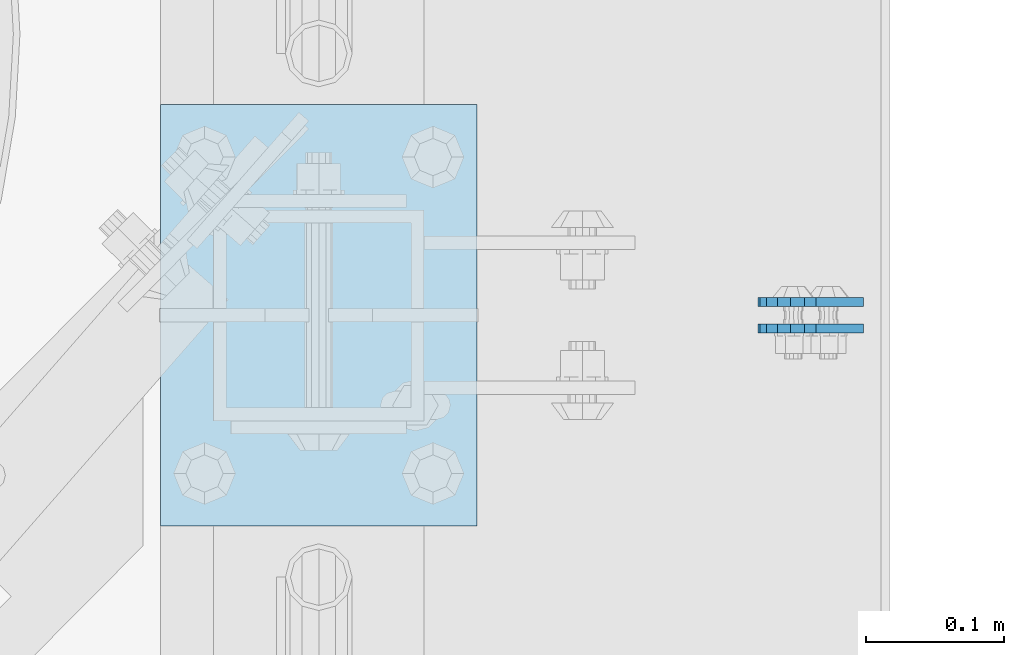
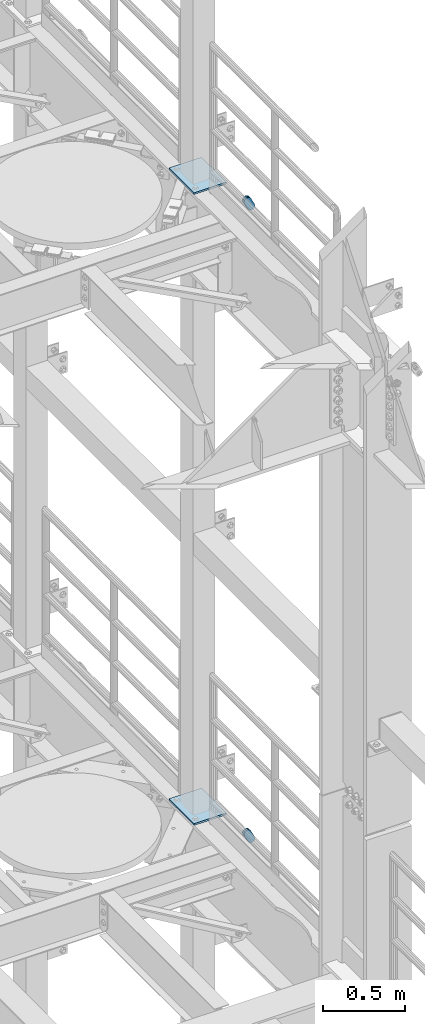
# One storey, part 1677 of 1876: 6 plates, 6 elements without a shape of their own.
"""IFC2X3 building model written with IfcOpenShell, lengths in millimetres."""

from ifc_helpers import new_model, si_unit, frame, origin_with_axes, place, context, subcontext, project, spatial, faceted_brep, material, type_object, element, aggregate, save


model = new_model("IFC2X3")

# Units and contexts
model_context = context("Model", 3, precision=1e-05, world=origin_with_axes())
body_context = subcontext(model_context, "Body", "Model", "MODEL_VIEW")
ifc_project = project(units=[si_unit("LENGTHUNIT", "METRE", prefix="MILLI"), si_unit("AREAUNIT", "SQUARE_METRE"), si_unit("VOLUMEUNIT", "CUBIC_METRE"), si_unit("MASSUNIT", "GRAM", prefix="KILO"), si_unit("TIMEUNIT", "SECOND"), si_unit("PLANEANGLEUNIT", "RADIAN"), si_unit("SOLIDANGLEUNIT", "STERADIAN"), si_unit("THERMODYNAMICTEMPERATUREUNIT", "DEGREE_CELSIUS"), si_unit("LUMINOUSINTENSITYUNIT", "LUMEN")], contexts=[model_context])

# Site, building, storey
site_placement = place(None, origin_with_axes())
site = spatial("IfcSite", under=ifc_project, at=site_placement, CompositionType="ELEMENT")
building_placement = place(site_placement, origin_with_axes())
building = spatial("IfcBuilding", under=site, at=building_placement, Name="Undefined", CompositionType="ELEMENT")
storey_placement = place(building_placement, origin_with_axes())
storey = spatial("IfcBuildingStorey", under=building, at=storey_placement, Name="Undefined", CompositionType="ELEMENT", Elevation=0.0)

# Assembly, plate
assembly_1_placement = place(storey_placement, origin_with_axes())
assembly_1 = element("IfcElementAssembly", 1, at=assembly_1_placement, inside=storey, Name="PLATE", AssemblyPlace="NOTDEFINED", PredefinedType="RIGID_FRAME")
ifc_material = material(Name="STEEL/A36")
plate_type_1 = type_object("IfcPlateType", PredefinedType="NOTDEFINED")
plate_1_placement = place(assembly_1_placement, frame((7974.16265106339, 3546.47500383818, 17725.1776774809), z_axis=(-0.894427191199917, 1.49999996210681e-08, -0.447213595099955), x_axis=(0.447213595099955, -6.99999707257281e-09, -0.894427191199917)))
plate_1 = element("IfcPlate", 2, at=plate_1_placement, type_object=plate_type_1, material=ifc_material, Name="PLATE", context=body_context, shape_type="Brep", body=[
    faceted_brep([(-8.59611645864788e-07, -3.17499999999654, 25.3999987589127), (1.93345873884391, -3.17499999999382, 35.1201580589886), (1.93345873884391, 3.17500000000564, 35.1201580589886), (-8.59611645864788e-07, 3.17500000000382, 25.3999987589132), (7.43948648259902, -3.17499999999109, 43.3605112870105), (7.43948648259902, 3.17500000000928, 43.3605112870105), (15.6798395242777, -3.17499999998654, 48.8665393096448), (15.6798395242777, 3.17500000001382, 48.8665393096448), (25.3999987589095, -3.17499999998199, 50.7999992370592), (25.3999987589095, 3.17500000001837, 50.7999992370592), (82.196130752618, -3.17499999998381, 50.7999992370605), (82.196130752618, 3.17500000001655, 50.7999992370642), (91.9162897887145, -3.17499999997926, 48.8665393918873), (91.9162897887145, 3.1750000000211, 48.8665393918909), (100.156642725027, -3.17499999997472, 43.3605115909359), (100.156642725027, 3.17500000002565, 43.3605115909395), (105.662670525982, -3.17499999997108, 35.1201586546285), (105.662670525986, 3.17500000002929, 35.1201586546358), (107.596130371159, -3.17499999996744, 25.3999996185757), (107.596130371159, 3.17500000003292, 25.3999996185794), (105.662670525981, -3.17499999996471, 15.6798405824902), (105.662670525981, 3.17500000003565, 15.6798405824939), (100.156642725024, -3.17499999996471, 7.43948764618654), (100.156642725025, 3.17500000003565, 7.43948764619017), (91.9162897887127, -3.17499999996562, 1.93345984522784), (91.9162897887127, 3.17500000003474, 1.93345984523148), (82.196130752618, -3.17499999996835, 4.54747350886464e-11), (82.196130752618, 3.1750000000311, 4.91127138957381e-11), (25.399998758905, -3.17499999999018, -8.64019966684282e-12), (25.399998758905, 3.17500000001019, -8.64019966684282e-12), (15.679839921364, -3.17499999999382, 1.9334597629304), (15.679839921364, 3.17500000000655, 1.9334597629304), (7.43948709043525, -3.17499999999654, 7.43948734220839), (7.43948709043525, 3.17500000000382, 7.43948734220885), (1.93345923228208, -3.17499999999654, 15.6798399868012), (1.93345923228208, 3.17500000000291, 15.6798399868012)], [[[0, 1, 2, 3]], [[1, 4, 5, 2]], [[4, 6, 7, 5]], [[6, 8, 9, 7]], [[8, 10, 11, 9]], [[10, 12, 13, 11]], [[12, 14, 15, 13]], [[14, 16, 17, 15]], [[16, 18, 19, 17]], [[18, 20, 21, 19]], [[20, 22, 23, 21]], [[22, 24, 25, 23]], [[24, 26, 27, 25]], [[26, 28, 29, 27]], [[28, 30, 31, 29]], [[30, 32, 33, 31]], [[32, 34, 35, 33]], [[34, 0, 3, 35]], [[5, 7, 9, 11, 13, 15, 17, 19, 21, 23, 25, 27, 29, 31, 33, 35, 3, 2]], [[34, 32, 30, 28, 26, 24, 22, 20, 18, 16, 14, 12, 10, 8, 6, 4, 1, 0]]]),
])
aggregate(assembly_1, [plate_1])

assembly_2_placement = place(storey_placement, origin_with_axes())
assembly_2 = element("IfcElementAssembly", 3, at=assembly_2_placement, inside=storey, Name="PLATE", AssemblyPlace="NOTDEFINED", PredefinedType="RIGID_FRAME")
plate_2_placement = place(assembly_2_placement, frame((7974.16265165997, 3565.53620014286, 17725.1776774809), z_axis=(-0.894427191199917, 1.49999996210681e-08, -0.447213595099955), x_axis=(0.447213595099955, -6.99999707257281e-09, -0.894427191199917)))
plate_2 = element("IfcPlate", 4, at=plate_2_placement, type_object=plate_type_1, material=ifc_material, Name="PLATE", context=body_context, shape_type="Brep", body=[
    faceted_brep([(-8.59611645864788e-07, -3.17499999999654, 25.3999987589127), (1.93345873884391, -3.17499999999382, 35.1201580589886), (1.93345873884391, 3.17500000000564, 35.1201580589886), (-8.59611645864788e-07, 3.17500000000382, 25.3999987589132), (7.43948648259902, -3.17499999999109, 43.3605112870105), (7.43948648259902, 3.17500000000928, 43.3605112870105), (15.6798395242777, -3.17499999998654, 48.8665393096448), (15.6798395242777, 3.17500000001382, 48.8665393096448), (25.3999987589095, -3.17499999998199, 50.7999992370592), (25.3999987589095, 3.17500000001837, 50.7999992370592), (82.196130752618, -3.17499999998381, 50.7999992370605), (82.196130752618, 3.17500000001655, 50.7999992370642), (91.9162897887145, -3.17499999997926, 48.8665393918873), (91.9162897887145, 3.1750000000211, 48.8665393918909), (100.156642725027, -3.17499999997472, 43.3605115909359), (100.156642725027, 3.17500000002565, 43.3605115909395), (105.662670525982, -3.17499999997108, 35.1201586546285), (105.662670525986, 3.17500000002929, 35.1201586546358), (107.596130371159, -3.17499999996744, 25.3999996185757), (107.596130371159, 3.17500000003292, 25.3999996185794), (105.662670525981, -3.17499999996471, 15.6798405824902), (105.662670525981, 3.17500000003565, 15.6798405824939), (100.156642725024, -3.17499999996471, 7.43948764618654), (100.156642725025, 3.17500000003565, 7.43948764619017), (91.9162897887127, -3.17499999996562, 1.93345984522784), (91.9162897887127, 3.17500000003474, 1.93345984523148), (82.196130752618, -3.17499999996835, 4.54747350886464e-11), (82.196130752618, 3.1750000000311, 4.91127138957381e-11), (25.399998758905, -3.17499999999018, -8.64019966684282e-12), (25.399998758905, 3.17500000001019, -8.64019966684282e-12), (15.679839921364, -3.17499999999382, 1.9334597629304), (15.679839921364, 3.17500000000655, 1.9334597629304), (7.43948709043525, -3.17499999999654, 7.43948734220839), (7.43948709043525, 3.17500000000382, 7.43948734220885), (1.93345923228208, -3.17499999999654, 15.6798399868012), (1.93345923228208, 3.17500000000291, 15.6798399868012)], [[[0, 1, 2, 3]], [[1, 4, 5, 2]], [[4, 6, 7, 5]], [[6, 8, 9, 7]], [[8, 10, 11, 9]], [[10, 12, 13, 11]], [[12, 14, 15, 13]], [[14, 16, 17, 15]], [[16, 18, 19, 17]], [[18, 20, 21, 19]], [[20, 22, 23, 21]], [[22, 24, 25, 23]], [[24, 26, 27, 25]], [[26, 28, 29, 27]], [[28, 30, 31, 29]], [[30, 32, 33, 31]], [[32, 34, 35, 33]], [[34, 0, 3, 35]], [[5, 7, 9, 11, 13, 15, 17, 19, 21, 23, 25, 27, 29, 31, 33, 35, 3, 2]], [[34, 32, 30, 28, 26, 24, 22, 20, 18, 16, 14, 12, 10, 8, 6, 4, 1, 0]]]),
])
aggregate(assembly_2, [plate_2])

assembly_3_placement = place(storey_placement, origin_with_axes())
assembly_3 = element("IfcElementAssembly", 5, at=assembly_3_placement, inside=storey, Name="PLATE", AssemblyPlace="NOTDEFINED", PredefinedType="RIGID_FRAME")
plate_3_placement = place(assembly_3_placement, frame((7974.16265106339, 3546.47500383818, 13038.8776774809), z_axis=(-0.894427191199917, 1.49999996210681e-08, -0.447213595099955), x_axis=(0.447213595099955, -6.99999707257281e-09, -0.894427191199917)))
plate_3 = element("IfcPlate", 6, at=plate_3_placement, type_object=plate_type_1, material=ifc_material, Name="PLATE", context=body_context, shape_type="Brep", body=[
    faceted_brep([(-8.59611645864788e-07, -3.17499999999654, 25.3999987589127), (1.93345873884391, -3.17499999999382, 35.1201580589886), (1.93345873884391, 3.17500000000564, 35.1201580589886), (-8.59611645864788e-07, 3.17500000000382, 25.3999987589132), (7.43948648259902, -3.17499999999109, 43.3605112870105), (7.43948648259902, 3.17500000000928, 43.3605112870105), (15.6798395242777, -3.17499999998654, 48.8665393096448), (15.6798395242777, 3.17500000001382, 48.8665393096448), (25.3999987589095, -3.17499999998199, 50.7999992370592), (25.3999987589095, 3.17500000001837, 50.7999992370592), (82.196130752618, -3.17499999998381, 50.7999992370605), (82.196130752618, 3.17500000001655, 50.7999992370642), (91.9162897887145, -3.17499999997926, 48.8665393918873), (91.9162897887145, 3.1750000000211, 48.8665393918909), (100.156642725027, -3.17499999997472, 43.3605115909359), (100.156642725027, 3.17500000002565, 43.3605115909395), (105.662670525982, -3.17499999997108, 35.1201586546285), (105.662670525986, 3.17500000002929, 35.1201586546358), (107.596130371159, -3.17499999996744, 25.3999996185757), (107.596130371159, 3.17500000003292, 25.3999996185794), (105.662670525981, -3.17499999996471, 15.6798405824902), (105.662670525981, 3.17500000003565, 15.6798405824939), (100.156642725024, -3.17499999996471, 7.43948764618654), (100.156642725025, 3.17500000003565, 7.43948764619017), (91.9162897887127, -3.17499999996562, 1.93345984522784), (91.9162897887127, 3.17500000003474, 1.93345984523148), (82.196130752618, -3.17499999996835, 4.54747350886464e-11), (82.196130752618, 3.1750000000311, 4.91127138957381e-11), (25.399998758905, -3.17499999999018, -8.64019966684282e-12), (25.399998758905, 3.17500000001019, -8.64019966684282e-12), (15.679839921364, -3.17499999999382, 1.9334597629304), (15.679839921364, 3.17500000000655, 1.9334597629304), (7.43948709043525, -3.17499999999654, 7.43948734220839), (7.43948709043525, 3.17500000000382, 7.43948734220885), (1.93345923228208, -3.17499999999654, 15.6798399868012), (1.93345923228208, 3.17500000000291, 15.6798399868012)], [[[0, 1, 2, 3]], [[1, 4, 5, 2]], [[4, 6, 7, 5]], [[6, 8, 9, 7]], [[8, 10, 11, 9]], [[10, 12, 13, 11]], [[12, 14, 15, 13]], [[14, 16, 17, 15]], [[16, 18, 19, 17]], [[18, 20, 21, 19]], [[20, 22, 23, 21]], [[22, 24, 25, 23]], [[24, 26, 27, 25]], [[26, 28, 29, 27]], [[28, 30, 31, 29]], [[30, 32, 33, 31]], [[32, 34, 35, 33]], [[34, 0, 3, 35]], [[5, 7, 9, 11, 13, 15, 17, 19, 21, 23, 25, 27, 29, 31, 33, 35, 3, 2]], [[34, 32, 30, 28, 26, 24, 22, 20, 18, 16, 14, 12, 10, 8, 6, 4, 1, 0]]]),
])
aggregate(assembly_3, [plate_3])

assembly_4_placement = place(storey_placement, origin_with_axes())
assembly_4 = element("IfcElementAssembly", 7, at=assembly_4_placement, inside=storey, Name="PLATE", AssemblyPlace="NOTDEFINED", PredefinedType="RIGID_FRAME")
plate_4_placement = place(assembly_4_placement, frame((7974.16265165997, 3565.53620014286, 13038.8776774809), z_axis=(-0.894427191199917, 1.49999996210681e-08, -0.447213595099955), x_axis=(0.447213595099955, -6.99999707257281e-09, -0.894427191199917)))
plate_4 = element("IfcPlate", 8, at=plate_4_placement, type_object=plate_type_1, material=ifc_material, Name="PLATE", context=body_context, shape_type="Brep", body=[
    faceted_brep([(-8.59611645864788e-07, -3.17499999999654, 25.3999987589127), (1.93345873884391, -3.17499999999382, 35.1201580589886), (1.93345873884391, 3.17500000000564, 35.1201580589886), (-8.59611645864788e-07, 3.17500000000382, 25.3999987589132), (7.43948648259902, -3.17499999999109, 43.3605112870105), (7.43948648259902, 3.17500000000928, 43.3605112870105), (15.6798395242777, -3.17499999998654, 48.8665393096448), (15.6798395242777, 3.17500000001382, 48.8665393096448), (25.3999987589095, -3.17499999998199, 50.7999992370592), (25.3999987589095, 3.17500000001837, 50.7999992370592), (82.196130752618, -3.17499999998381, 50.7999992370605), (82.196130752618, 3.17500000001655, 50.7999992370642), (91.9162897887145, -3.17499999997926, 48.8665393918873), (91.9162897887145, 3.1750000000211, 48.8665393918909), (100.156642725027, -3.17499999997472, 43.3605115909359), (100.156642725027, 3.17500000002565, 43.3605115909395), (105.662670525982, -3.17499999997108, 35.1201586546285), (105.662670525986, 3.17500000002929, 35.1201586546358), (107.596130371159, -3.17499999996744, 25.3999996185757), (107.596130371159, 3.17500000003292, 25.3999996185794), (105.662670525981, -3.17499999996471, 15.6798405824902), (105.662670525981, 3.17500000003565, 15.6798405824939), (100.156642725024, -3.17499999996471, 7.43948764618654), (100.156642725025, 3.17500000003565, 7.43948764619017), (91.9162897887127, -3.17499999996562, 1.93345984522784), (91.9162897887127, 3.17500000003474, 1.93345984523148), (82.196130752618, -3.17499999996835, 4.54747350886464e-11), (82.196130752618, 3.1750000000311, 4.91127138957381e-11), (25.399998758905, -3.17499999999018, -8.64019966684282e-12), (25.399998758905, 3.17500000001019, -8.64019966684282e-12), (15.679839921364, -3.17499999999382, 1.9334597629304), (15.679839921364, 3.17500000000655, 1.9334597629304), (7.43948709043525, -3.17499999999654, 7.43948734220839), (7.43948709043525, 3.17500000000382, 7.43948734220885), (1.93345923228208, -3.17499999999654, 15.6798399868012), (1.93345923228208, 3.17500000000291, 15.6798399868012)], [[[0, 1, 2, 3]], [[1, 4, 5, 2]], [[4, 6, 7, 5]], [[6, 8, 9, 7]], [[8, 10, 11, 9]], [[10, 12, 13, 11]], [[12, 14, 15, 13]], [[14, 16, 17, 15]], [[16, 18, 19, 17]], [[18, 20, 21, 19]], [[20, 22, 23, 21]], [[22, 24, 25, 23]], [[24, 26, 27, 25]], [[26, 28, 29, 27]], [[28, 30, 31, 29]], [[30, 32, 33, 31]], [[32, 34, 35, 33]], [[34, 0, 3, 35]], [[5, 7, 9, 11, 13, 15, 17, 19, 21, 23, 25, 27, 29, 31, 33, 35, 3, 2]], [[34, 32, 30, 28, 26, 24, 22, 20, 18, 16, 14, 12, 10, 8, 6, 4, 1, 0]]]),
])
aggregate(assembly_4, [plate_4])

assembly_5_placement = place(storey_placement, origin_with_axes())
assembly_5 = element("IfcElementAssembly", 9, at=assembly_5_placement, inside=storey, Name="BEAM", AssemblyPlace="NOTDEFINED", PredefinedType="RIGID_FRAME")
plate_type_2 = type_object("IfcPlateType", PredefinedType="NOTDEFINED")
plate_5_placement = place(assembly_5_placement, frame((7505.7, 3403.6, 17989.55), z_axis=(0.0, 1.0, 0.0), x_axis=(1.0, 0.0, 0.0)))
plate_5 = element("IfcPlate", 10, at=plate_5_placement, type_object=plate_type_2, material=ifc_material, Name="PLATE", context=body_context, shape_type="Brep", body=[
    faceted_brep([(0.0, -6.35000000000036, 0.0), (0.0, -6.35000000000036, 304.799987792969), (0.0, 6.35000000000036, 304.799987792969), (0.0, 6.35000000000036, 0.0), (228.600006103516, -6.34999999999854, 304.799987792969), (228.600006103516, 6.34999999999854, 304.799987792969), (228.600006103516, -6.34999999999854, 0.0), (228.600006103516, 6.34999999999854, 0.0)], [[[0, 1, 2, 3]], [[1, 4, 5, 2]], [[4, 6, 7, 5]], [[6, 0, 3, 7]], [[5, 7, 3, 2]], [[6, 4, 1, 0]]]),
])
aggregate(assembly_5, [plate_5])

assembly_6_placement = place(storey_placement, origin_with_axes())
assembly_6 = element("IfcElementAssembly", 11, at=assembly_6_placement, inside=storey, Name="BEAM", AssemblyPlace="NOTDEFINED", PredefinedType="RIGID_FRAME")
plate_6_placement = place(assembly_6_placement, frame((7505.7, 3403.6, 13315.95), z_axis=(0.0, 1.0, 0.0), x_axis=(1.0, 0.0, 0.0)))
plate_6 = element("IfcPlate", 12, at=plate_6_placement, type_object=plate_type_2, material=ifc_material, Name="PLATE", context=body_context, shape_type="Brep", body=[
    faceted_brep([(0.0, -6.35000000000036, 0.0), (0.0, -6.35000000000036, 304.799987792969), (0.0, 6.35000000000036, 304.799987792969), (0.0, 6.35000000000036, 0.0), (228.600006103516, -6.34999999999854, 304.799987792969), (228.600006103516, 6.34999999999854, 304.799987792969), (228.600006103516, -6.34999999999854, 0.0), (228.600006103516, 6.34999999999854, 0.0)], [[[0, 1, 2, 3]], [[1, 4, 5, 2]], [[4, 6, 7, 5]], [[6, 0, 3, 7]], [[5, 7, 3, 2]], [[6, 4, 1, 0]]]),
])
aggregate(assembly_6, [plate_6])

save(model, "model.ifc")
